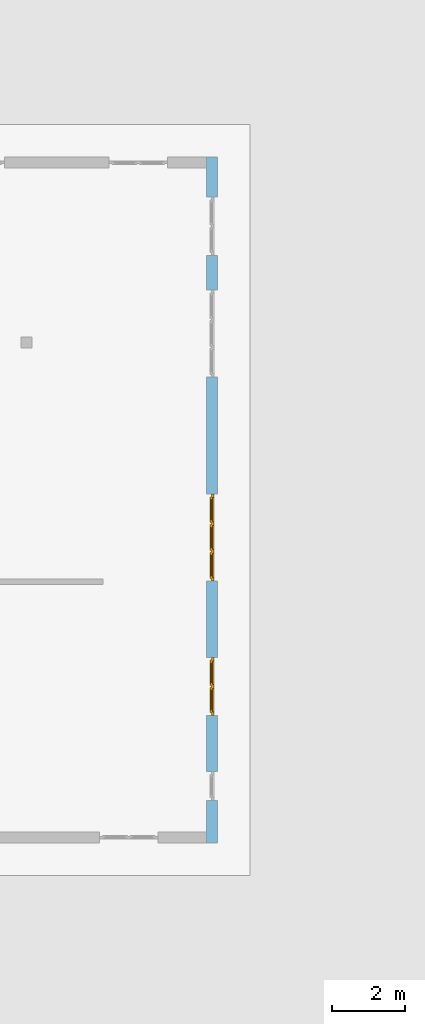
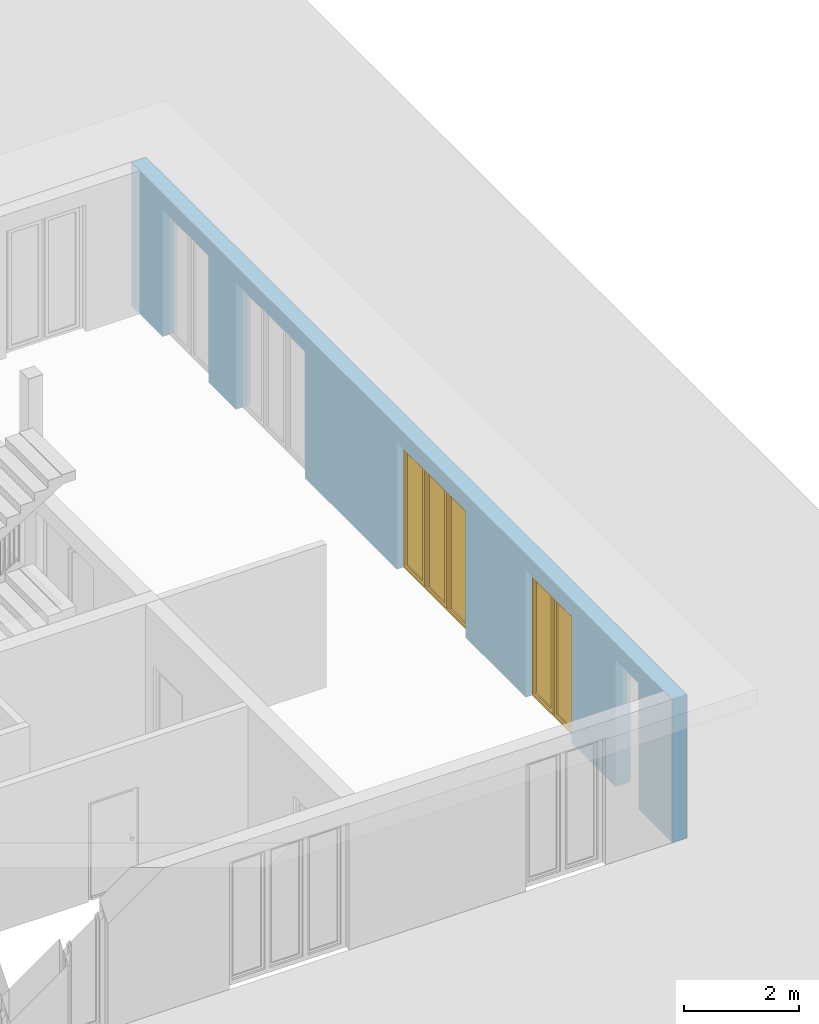
# One storey, part 13 of 23: 2 windows, 5 openings, plus 1 element that does not belong to this part.
"""IFC4 building model written with IfcOpenShell, lengths in metres."""

from ifc_helpers import new_model, entity, si_unit, converted_unit, derived_unit, direction, frame, origin_with_axes, place, context, subcontext, project, spatial, polygons, source, transform, mapped, material, type_object, element, fill, save


model = new_model("IFC4")

# Units and contexts
model_context = context("Model", 3, precision=1e-05, world=origin_with_axes(), true_north=direction((0.0, 1.0)))
body_context = subcontext(model_context, "Body", "Model", "MODEL_VIEW")
ifc_project = project(units=[si_unit("LENGTHUNIT", "METRE"), si_unit("AREAUNIT", "SQUARE_METRE"), si_unit("VOLUMEUNIT", "CUBIC_METRE"), converted_unit("PLANEANGLEUNIT", "DEGREE", entity("IfcPlaneAngleMeasure", 0.0174532925199), si_unit("PLANEANGLEUNIT", "RADIAN"), dimensions=[0, 0, 0, 0, 0, 0, 0]), converted_unit("TIMEUNIT", "Year", entity("IfcTimeMeasure", 31556926.0), si_unit("TIMEUNIT", "SECOND"), dimensions=[0, 0, 1, 0, 0, 0, 0]), si_unit("MASSUNIT", "GRAM", prefix="KILO"), si_unit("THERMODYNAMICTEMPERATUREUNIT", "DEGREE_CELSIUS"), si_unit("LUMINOUSINTENSITYUNIT", "LUMEN"), si_unit("ENERGYUNIT", "JOULE", prefix="MEGA"), derived_unit("THERMALCONDUCTANCEUNIT", [(si_unit("POWERUNIT", "WATT"), 1), (si_unit("LENGTHUNIT", "METRE"), -1), (si_unit("THERMODYNAMICTEMPERATUREUNIT", "KELVIN"), -1)]), derived_unit("SPECIFICHEATCAPACITYUNIT", [(si_unit("ENERGYUNIT", "JOULE"), 1), (si_unit("MASSUNIT", "GRAM", prefix="KILO"), -1), (si_unit("THERMODYNAMICTEMPERATUREUNIT", "KELVIN"), -1)]), derived_unit("MASSDENSITYUNIT", [(si_unit("MASSUNIT", "GRAM", prefix="KILO"), 1), (si_unit("VOLUMEUNIT", "CUBIC_METRE"), -1)])], contexts=[model_context])

# Site, building, storey
site_placement = place(None, origin_with_axes())
site = spatial("IfcSite", under=ifc_project, at=site_placement, CompositionType="ELEMENT")
building_placement = place(site_placement, origin_with_axes())
building = spatial("IfcBuilding", under=site, at=building_placement, CompositionType="ELEMENT")
storey_placement = place(building_placement, origin_with_axes())
storey = spatial("IfcBuildingStorey", under=building, at=storey_placement, Name="0. Geschoss", CompositionType="ELEMENT", Elevation=0.0)

# Wall, openings, windows
ifc_material = material()
wall_type = type_object("IfcWallType", Name="300", PredefinedType="NOTDEFINED")
wall_placement = place(storey_placement, frame((9.3378006196, -9.92881223104, 0.0), z_axis=(0.0, 0.0, 1.0), x_axis=(0.0, 1.0, 0.0)))
wall = element("IfcWall", 1, at=wall_placement, inside=storey, type_object=wall_type, material=ifc_material, Name="Wand-001", PredefinedType="NOTDEFINED", context=body_context, shape_type="Tessellation", body=[
    polygons([(1.16441876325, 0.1, 2.7), (1.96441876325, 0.1, 2.7), (1.96441876325, 0.0, 2.7), (1.16441876325, 0.0, 2.7), (1.16441876325, 0.3, 2.7), (1.96441876325, 0.3, 2.7), (1.96441876325, 0.1, 0.0), (1.96441876325, 0.0, 0.0), (18.85, 0.0, 3.05), (0.0, 0.0, 3.05), (0.0, 0.0, 0.0), (1.16441876325, 0.0, 0.0), (3.5, 0.0, 0.0), (3.5, 0.0, 2.7), (5.1, 0.0, 2.7), (5.1, 0.0, 0.0), (7.1921181063, 0.0, 0.0), (7.1921181063, 0.0, 2.7), (9.5921181063, 0.0, 2.7), (9.5921181063, 0.0, 0.0), (12.8, 0.0, 0.0), (12.8, 0.0, 2.7), (15.2, 0.0, 2.7), (15.2, 0.0, 0.0), (16.15, 0.0, 0.0), (16.15, 0.0, 2.7), (17.75, 0.0, 2.7), (17.75, 0.0, 0.0), (18.85, 0.0, 0.0), (1.16441876325, 0.1, 0.0), (1.16441876325, 0.3, 0.0), (0.0, 0.3, 0.0), (0.0, 0.3, 3.05), (18.85, 0.3, 3.05), (18.85, 0.3, 0.0), (17.75, 0.3, 0.0), (17.75, 0.3, 2.7), (16.15, 0.3, 2.7), (16.15, 0.3, 0.0), (15.2, 0.3, 0.0), (15.2, 0.3, 2.7), (12.8, 0.3, 2.7), (12.8, 0.3, 0.0), (9.5921181063, 0.3, 0.0), (9.5921181063, 0.3, 2.7), (7.1921181063, 0.3, 2.7), (7.1921181063, 0.3, 0.0), (5.1, 0.3, 0.0), (5.1, 0.3, 2.7), (3.5, 0.3, 2.7), (3.5, 0.3, 0.0), (1.96441876325, 0.3, 0.0), (3.5, 0.1, 0.0), (3.5, 0.1, 2.7), (5.1, 0.1, 2.7), (5.1, 0.1, 0.0), (7.1921181063, 0.1, 0.0), (7.1921181063, 0.1, 2.7), (9.5921181063, 0.1, 2.7), (9.5921181063, 0.1, 0.0), (12.8, 0.1, 0.0), (12.8, 0.1, 2.7), (15.2, 0.1, 2.7), (15.2, 0.1, 0.0), (16.15, 0.1, 0.0), (16.15, 0.1, 2.7), (17.75, 0.1, 2.7), (17.75, 0.1, 0.0)], [[[1, 2, 3, 4]], [[2, 1, 5, 6]], [[2, 7, 8, 3]], [[9, 10, 11, 12, 4, 3, 8, 13, 14, 15, 16, 17, 18, 19, 20, 21, 22, 23, 24, 25, 26, 27, 28, 29]], [[30, 1, 4, 12]], [[1, 30, 31, 5]], [[5, 31, 32, 33, 34, 35, 36, 37, 38, 39, 40, 41, 42, 43, 44, 45, 46, 47, 48, 49, 50, 51, 52, 6]], [[7, 2, 6, 52]], [[7, 52, 51, 53, 13, 8]], [[9, 34, 33, 10]], [[33, 32, 11, 10]], [[31, 30, 12, 11, 32]], [[14, 13, 53, 54]], [[15, 14, 54, 55]], [[16, 15, 55, 56]], [[56, 48, 47, 57, 17, 16]], [[57, 58, 18, 17]], [[58, 59, 19, 18]], [[59, 60, 20, 19]], [[60, 44, 43, 61, 21, 20]], [[22, 21, 61, 62]], [[23, 22, 62, 63]], [[24, 23, 63, 64]], [[64, 40, 39, 65, 25, 24]], [[65, 66, 26, 25]], [[66, 67, 27, 26]], [[67, 68, 28, 27]], [[36, 35, 29, 28, 68]], [[9, 29, 35, 34]], [[68, 67, 37, 36]], [[67, 66, 38, 37]], [[66, 65, 39, 38]], [[41, 40, 64, 63]], [[42, 41, 63, 62]], [[43, 42, 62, 61]], [[60, 59, 45, 44]], [[59, 58, 46, 45]], [[58, 57, 47, 46]], [[49, 48, 56, 55]], [[50, 49, 55, 54]], [[51, 50, 54, 53]]], closed=True),
])
opening_1_placement = place(wall_placement, frame((16.95, 0.0, 0.0), z_axis=(0.0, 0.0, 1.0), x_axis=(1.0, 0.0, 0.0)))
element("IfcOpeningElement", 2, at=opening_1_placement, cuts=wall, Name="Fenster-001", context=body_context, identifier="Reference", shape_type="Tessellation", body=[
    polygons([(0.8, 0.1, 0.0), (0.8, 0.1, 2.7), (0.8, -0.000999999999999, 2.7), (0.8, -0.000999999999999, 0.0), (0.8, 0.301, 0.0), (0.8, 0.301, 2.7), (-0.8, 0.1, 2.7), (-0.8, -0.000999999999999, 2.7), (-0.8, 0.301, 2.7), (-0.8, -0.000999999999999, 0.0), (-0.8, 0.1, 0.0), (-0.8, 0.301, 0.0)], [[[1, 2, 3, 4]], [[2, 1, 5, 6]], [[7, 8, 3, 2, 6, 9]], [[8, 10, 4, 3]], [[1, 4, 10, 11, 12, 5]], [[6, 5, 12, 9]], [[7, 11, 10, 8]], [[11, 7, 9, 12]]], closed=True),
])
opening_2_placement = place(wall_placement, frame((14.0, 0.0, 0.0), z_axis=(0.0, 0.0, 1.0), x_axis=(1.0, 0.0, 0.0)))
element("IfcOpeningElement", 3, at=opening_2_placement, cuts=wall, Name="Fenster-002", context=body_context, identifier="Reference", shape_type="Tessellation", body=[
    polygons([(1.2, 0.1, 0.0), (1.2, 0.1, 2.7), (1.2, -0.000999999999999, 2.7), (1.2, -0.000999999999999, 0.0), (1.2, 0.301, 0.0), (1.2, 0.301, 2.7), (-1.2, 0.1, 2.7), (-1.2, -0.000999999999999, 2.7), (-1.2, 0.301, 2.7), (-1.2, -0.000999999999999, 0.0), (-1.2, 0.1, 0.0), (-1.2, 0.301, 0.0)], [[[1, 2, 3, 4]], [[2, 1, 5, 6]], [[7, 8, 3, 2, 6, 9]], [[8, 10, 4, 3]], [[1, 4, 10, 11, 12, 5]], [[6, 5, 12, 9]], [[7, 11, 10, 8]], [[11, 7, 9, 12]]], closed=True),
])
opening_3_placement = place(wall_placement, frame((8.3921181063, 0.0, 0.0), z_axis=(0.0, 0.0, 1.0), x_axis=(1.0, 0.0, 0.0)))
opening_3 = element("IfcOpeningElement", 4, at=opening_3_placement, cuts=wall, Name="Fenster-002", context=body_context, identifier="Reference", shape_type="Tessellation", body=[
    polygons([(1.2, 0.1, 0.0), (1.2, 0.1, 2.7), (1.2, -0.000999999999999, 2.7), (1.2, -0.000999999999999, 0.0), (1.2, 0.301, 0.0), (1.2, 0.301, 2.7), (-1.2, 0.1, 2.7), (-1.2, -0.000999999999999, 2.7), (-1.2, 0.301, 2.7), (-1.2, -0.000999999999999, 0.0), (-1.2, 0.1, 0.0), (-1.2, 0.301, 0.0)], [[[1, 2, 3, 4]], [[2, 1, 5, 6]], [[7, 8, 3, 2, 6, 9]], [[8, 10, 4, 3]], [[1, 4, 10, 11, 12, 5]], [[6, 5, 12, 9]], [[7, 11, 10, 8]], [[11, 7, 9, 12]]], closed=True),
])
opening_4_placement = place(wall_placement, frame((4.3, 0.0, 0.0), z_axis=(0.0, 0.0, 1.0), x_axis=(1.0, 0.0, 0.0)))
opening_4 = element("IfcOpeningElement", 5, at=opening_4_placement, cuts=wall, Name="Fenster-001", context=body_context, identifier="Reference", shape_type="Tessellation", body=[
    polygons([(0.8, 0.1, 0.0), (0.8, 0.1, 2.7), (0.8, -0.000999999999999, 2.7), (0.8, -0.000999999999999, 0.0), (0.8, 0.301, 0.0), (0.8, 0.301, 2.7), (-0.8, 0.1, 2.7), (-0.8, -0.000999999999999, 2.7), (-0.8, 0.301, 2.7), (-0.8, -0.000999999999999, 0.0), (-0.8, 0.1, 0.0), (-0.8, 0.301, 0.0)], [[[1, 2, 3, 4]], [[2, 1, 5, 6]], [[7, 8, 3, 2, 6, 9]], [[8, 10, 4, 3]], [[1, 4, 10, 11, 12, 5]], [[6, 5, 12, 9]], [[7, 11, 10, 8]], [[11, 7, 9, 12]]], closed=True),
])
opening_5_placement = place(wall_placement, frame((1.56441876325, 0.0, 0.0), z_axis=(0.0, 0.0, 1.0), x_axis=(1.0, 0.0, 0.0)))
element("IfcOpeningElement", 6, at=opening_5_placement, cuts=wall, Name="Fenster-003", context=body_context, identifier="Reference", shape_type="Tessellation", body=[
    polygons([(0.4, 0.1, 0.0), (0.4, 0.1, 2.7), (0.4, -0.000999999999999, 2.7), (0.4, -0.000999999999999, 0.0), (0.4, 0.301, 0.0), (0.4, 0.301, 2.7), (-0.4, 0.1, 2.7), (-0.4, -0.000999999999999, 2.7), (-0.4, 0.301, 2.7), (-0.4, -0.000999999999999, 0.0), (-0.4, 0.1, 0.0), (-0.4, 0.301, 0.0)], [[[1, 2, 3, 4]], [[2, 1, 5, 6]], [[7, 8, 3, 2, 6, 9]], [[8, 10, 4, 3]], [[1, 4, 10, 11, 12, 5]], [[6, 5, 12, 9]], [[7, 11, 10, 8]], [[11, 7, 9, 12]]], closed=True),
])
window_type_1 = type_object("IfcWindowType", Name="3-1+1+1 26", PartitioningType="TRIPLE_PANEL_VERTICAL", PredefinedType="WINDOW")
shared_shape_1 = source(origin_with_axes(), body_context, "Body", "Tessellation", [
    polygons([(-1.2, -0.07, 0.0), (-1.2, 0.0, 0.0), (-1.1, 0.0, 0.1), (-1.1, -0.07, 0.1), (-1.2, -0.07, 2.7), (-1.2, 0.0, 2.7), (-1.1, 0.0, 2.6), (-1.1, -0.07, 2.6)], [[[1, 2, 3, 4]], [[5, 6, 2, 1]], [[2, 6, 7, 3]], [[4, 3, 7, 8]], [[1, 4, 8, 5]], [[8, 7, 6, 5]]], closed=True),
    polygons([(1.2, -0.07, 0.0), (1.2, 0.0, 0.0), (1.2, 0.0, 2.7), (1.2, -0.07, 2.7), (1.1, -0.07, 0.1), (1.1, 0.0, 0.1), (1.1, 0.0, 2.6), (1.1, -0.07, 2.6)], [[[1, 2, 3, 4]], [[5, 6, 2, 1]], [[2, 6, 7, 3]], [[4, 3, 7, 8]], [[1, 4, 8, 5]], [[8, 7, 6, 5]]], closed=True),
    polygons([(-1.2, -0.07, 0.0), (-1.2, 0.0, 0.0), (1.2, 0.0, 0.0), (1.2, -0.07, 0.0), (-1.1, -0.07, 0.1), (-1.1, 0.0, 0.1), (-0.433333333333, 0.0, 0.1), (-0.333333333333, 0.0, 0.1), (0.333333333333, 0.0, 0.1), (0.433333333333, 0.0, 0.1), (1.1, 0.0, 0.1), (1.1, -0.07, 0.1), (0.433333333333, -0.07, 0.1), (0.333333333333, -0.07, 0.1), (-0.333333333333, -0.07, 0.1), (-0.433333333333, -0.07, 0.1)], [[[1, 2, 3, 4]], [[5, 6, 2, 1]], [[2, 6, 7, 8, 9, 10, 11, 3]], [[4, 3, 11, 12]], [[1, 4, 12, 13, 14, 15, 16, 5]], [[16, 7, 6, 5]], [[15, 8, 7, 16]], [[14, 9, 8, 15]], [[13, 10, 9, 14]], [[12, 11, 10, 13]]], closed=True),
    polygons([(-1.2, -0.07, 2.7), (-1.2, 0.0, 2.7), (-1.1, 0.0, 2.6), (-1.1, -0.07, 2.6), (1.2, -0.07, 2.7), (1.2, 0.0, 2.7), (1.1, 0.0, 2.6), (0.433333333333, 0.0, 2.6), (0.333333333333, 0.0, 2.6), (-0.333333333333, 0.0, 2.6), (-0.433333333333, 0.0, 2.6), (-0.433333333333, -0.07, 2.6), (-0.333333333333, -0.07, 2.6), (0.333333333333, -0.07, 2.6), (0.433333333333, -0.07, 2.6), (1.1, -0.07, 2.6)], [[[1, 2, 3, 4]], [[5, 6, 2, 1]], [[2, 6, 7, 8, 9, 10, 11, 3]], [[4, 3, 11, 12]], [[1, 4, 12, 13, 14, 15, 16, 5]], [[16, 7, 6, 5]], [[15, 8, 7, 16]], [[14, 9, 8, 15]], [[13, 10, 9, 14]], [[12, 11, 10, 13]]], closed=True),
    polygons([(0.333333333333, -0.07, 0.1), (0.333333333333, 0.0, 0.1), (0.433333333333, 0.0, 0.1), (0.433333333333, -0.07, 0.1), (0.333333333333, -0.07, 2.6), (0.333333333333, 0.0, 2.6), (0.433333333333, 0.0, 2.6), (0.433333333333, -0.07, 2.6)], [[[1, 2, 3, 4]], [[5, 6, 2, 1]], [[2, 6, 7, 3]], [[4, 3, 7, 8]], [[1, 4, 8, 5]], [[8, 7, 6, 5]]], closed=True),
    polygons([(-0.433333333333, -0.07, 0.1), (-0.433333333333, 0.0, 0.1), (-0.333333333333, 0.0, 0.1), (-0.333333333333, -0.07, 0.1), (-0.433333333333, -0.07, 2.6), (-0.433333333333, 0.0, 2.6), (-0.333333333333, 0.0, 2.6), (-0.333333333333, -0.07, 2.6)], [[[1, 2, 3, 4]], [[5, 6, 2, 1]], [[2, 6, 7, 3]], [[4, 3, 7, 8]], [[1, 4, 8, 5]], [[8, 7, 6, 5]]], closed=True),
    polygons([(-1.12, 0.0, 0.08), (-1.12, 0.03, 0.08), (-1.05, 0.03, 0.15), (-1.05, 0.0, 0.15), (-1.12, 0.0, 2.62), (-1.12, 0.03, 2.62), (-1.05, 0.03, 2.55), (-1.05, 0.0, 2.55)], [[[1, 2, 3, 4]], [[5, 6, 2, 1]], [[2, 6, 7, 3]], [[4, 3, 7, 8]], [[1, 4, 8, 5]], [[8, 7, 6, 5]]], closed=True),
    polygons([(-0.413333333333, 0.0, 0.08), (-0.483333333333, 0.0, 0.15), (-0.483333333333, 0.03, 0.15), (-0.413333333333, 0.03, 0.08), (-0.413333333333, 0.0, 2.62), (-0.483333333333, 0.0, 2.55), (-0.483333333333, 0.03, 2.55), (-0.413333333333, 0.03, 2.62)], [[[1, 2, 3, 4]], [[1, 5, 6, 2]], [[2, 6, 7, 3]], [[4, 3, 7, 8]], [[5, 1, 4, 8]], [[6, 5, 8, 7]]], closed=True),
    polygons([(-1.12, 0.0, 0.08), (-1.12, 0.03, 0.08), (-0.413333333333, 0.03, 0.08), (-0.413333333333, 0.0, 0.08), (-1.05, 0.0, 0.15), (-1.05, 0.03, 0.15), (-0.483333333333, 0.03, 0.15), (-0.483333333333, 0.0, 0.15)], [[[1, 2, 3, 4]], [[5, 6, 2, 1]], [[2, 6, 7, 3]], [[4, 3, 7, 8]], [[1, 4, 8, 5]], [[8, 7, 6, 5]]], closed=True),
    polygons([(-1.12, 0.0, 2.62), (-0.413333333333, 0.0, 2.62), (-0.413333333333, 0.03, 2.62), (-1.12, 0.03, 2.62), (-1.05, 0.0, 2.55), (-0.483333333333, 0.0, 2.55), (-0.483333333333, 0.03, 2.55), (-1.05, 0.03, 2.55)], [[[1, 2, 3, 4]], [[1, 5, 6, 2]], [[2, 6, 7, 3]], [[4, 3, 7, 8]], [[5, 1, 4, 8]], [[6, 5, 8, 7]]], closed=True),
    polygons([(-1.1, -0.03, 0.1), (-1.1, 0.0, 0.1), (-1.05, 0.0, 0.15), (-1.05, -0.03, 0.15), (-1.1, -0.03, 2.6), (-1.1, 0.0, 2.6), (-1.05, 0.0, 2.55), (-1.05, -0.03, 2.55)], [[[1, 2, 3, 4]], [[5, 6, 2, 1]], [[2, 6, 7, 3]], [[4, 3, 7, 8]], [[1, 4, 8, 5]], [[8, 7, 6, 5]]], closed=True),
    polygons([(-0.433333333333, -0.03, 0.1), (-0.483333333333, -0.03, 0.15), (-0.483333333333, 0.0, 0.15), (-0.433333333333, 0.0, 0.1), (-0.433333333333, -0.03, 2.6), (-0.483333333333, -0.03, 2.55), (-0.483333333333, 0.0, 2.55), (-0.433333333333, 0.0, 2.6)], [[[1, 2, 3, 4]], [[1, 5, 6, 2]], [[2, 6, 7, 3]], [[4, 3, 7, 8]], [[5, 1, 4, 8]], [[6, 5, 8, 7]]], closed=True),
    polygons([(-1.1, -0.03, 0.1), (-1.1, 0.0, 0.1), (-0.433333333333, 0.0, 0.1), (-0.433333333333, -0.03, 0.1), (-1.05, -0.03, 0.15), (-1.05, 0.0, 0.15), (-0.483333333333, 0.0, 0.15), (-0.483333333333, -0.03, 0.15)], [[[1, 2, 3, 4]], [[5, 6, 2, 1]], [[2, 6, 7, 3]], [[4, 3, 7, 8]], [[1, 4, 8, 5]], [[8, 7, 6, 5]]], closed=True),
    polygons([(-1.1, -0.03, 2.6), (-0.433333333333, -0.03, 2.6), (-0.433333333333, 0.0, 2.6), (-1.1, 0.0, 2.6), (-1.05, -0.03, 2.55), (-0.483333333333, -0.03, 2.55), (-0.483333333333, 0.0, 2.55), (-1.05, 0.0, 2.55)], [[[1, 2, 3, 4]], [[1, 5, 6, 2]], [[2, 6, 7, 3]], [[4, 3, 7, 8]], [[5, 1, 4, 8]], [[6, 5, 8, 7]]], closed=True),
    polygons([(-1.05, -0.005, 0.15), (-1.05, 0.005, 0.15), (-0.483333333333, 0.005, 0.15), (-0.483333333333, -0.005, 0.15), (-1.05, -0.005, 2.55), (-1.05, 0.005, 2.55), (-0.483333333333, 0.005, 2.55), (-0.483333333333, -0.005, 2.55)], [[[1, 2, 3, 4]], [[5, 6, 2, 1]], [[2, 6, 7, 3]], [[4, 3, 7, 8]], [[1, 4, 8, 5]], [[8, 7, 6, 5]]], closed=True),
    polygons([(-0.353333333333, 0.0, 0.08), (-0.353333333333, 0.03, 0.08), (-0.283333333333, 0.03, 0.15), (-0.283333333333, 0.0, 0.15), (-0.353333333333, 0.0, 2.62), (-0.353333333333, 0.03, 2.62), (-0.283333333333, 0.03, 2.55), (-0.283333333333, 0.0, 2.55)], [[[1, 2, 3, 4]], [[5, 6, 2, 1]], [[2, 6, 7, 3]], [[4, 3, 7, 8]], [[1, 4, 8, 5]], [[8, 7, 6, 5]]], closed=True),
    polygons([(0.353333333333, 0.0, 0.08), (0.283333333333, 0.0, 0.15), (0.283333333333, 0.03, 0.15), (0.353333333333, 0.03, 0.08), (0.353333333333, 0.0, 2.62), (0.283333333333, 0.0, 2.55), (0.283333333333, 0.03, 2.55), (0.353333333333, 0.03, 2.62)], [[[1, 2, 3, 4]], [[1, 5, 6, 2]], [[2, 6, 7, 3]], [[4, 3, 7, 8]], [[5, 1, 4, 8]], [[6, 5, 8, 7]]], closed=True),
    polygons([(-0.353333333333, 0.0, 0.08), (-0.353333333333, 0.03, 0.08), (0.353333333333, 0.03, 0.08), (0.353333333333, 0.0, 0.08), (-0.283333333333, 0.0, 0.15), (-0.283333333333, 0.03, 0.15), (0.283333333333, 0.03, 0.15), (0.283333333333, 0.0, 0.15)], [[[1, 2, 3, 4]], [[5, 6, 2, 1]], [[2, 6, 7, 3]], [[4, 3, 7, 8]], [[1, 4, 8, 5]], [[8, 7, 6, 5]]], closed=True),
    polygons([(-0.353333333333, 0.0, 2.62), (0.353333333333, 0.0, 2.62), (0.353333333333, 0.03, 2.62), (-0.353333333333, 0.03, 2.62), (-0.283333333333, 0.0, 2.55), (0.283333333333, 0.0, 2.55), (0.283333333333, 0.03, 2.55), (-0.283333333333, 0.03, 2.55)], [[[1, 2, 3, 4]], [[1, 5, 6, 2]], [[2, 6, 7, 3]], [[4, 3, 7, 8]], [[5, 1, 4, 8]], [[6, 5, 8, 7]]], closed=True),
    polygons([(-0.333333333333, -0.03, 0.1), (-0.333333333333, 0.0, 0.1), (-0.283333333333, 0.0, 0.15), (-0.283333333333, -0.03, 0.15), (-0.333333333333, -0.03, 2.6), (-0.333333333333, 0.0, 2.6), (-0.283333333333, 0.0, 2.55), (-0.283333333333, -0.03, 2.55)], [[[1, 2, 3, 4]], [[5, 6, 2, 1]], [[2, 6, 7, 3]], [[4, 3, 7, 8]], [[1, 4, 8, 5]], [[8, 7, 6, 5]]], closed=True),
    polygons([(0.333333333333, -0.03, 0.1), (0.283333333333, -0.03, 0.15), (0.283333333333, 0.0, 0.15), (0.333333333333, 0.0, 0.1), (0.333333333333, -0.03, 2.6), (0.283333333333, -0.03, 2.55), (0.283333333333, 0.0, 2.55), (0.333333333333, 0.0, 2.6)], [[[1, 2, 3, 4]], [[1, 5, 6, 2]], [[2, 6, 7, 3]], [[4, 3, 7, 8]], [[5, 1, 4, 8]], [[6, 5, 8, 7]]], closed=True),
    polygons([(-0.333333333333, -0.03, 0.1), (-0.333333333333, 0.0, 0.1), (0.333333333333, 0.0, 0.1), (0.333333333333, -0.03, 0.1), (-0.283333333333, -0.03, 0.15), (-0.283333333333, 0.0, 0.15), (0.283333333333, 0.0, 0.15), (0.283333333333, -0.03, 0.15)], [[[1, 2, 3, 4]], [[5, 6, 2, 1]], [[2, 6, 7, 3]], [[4, 3, 7, 8]], [[1, 4, 8, 5]], [[8, 7, 6, 5]]], closed=True),
    polygons([(-0.333333333333, -0.03, 2.6), (0.333333333333, -0.03, 2.6), (0.333333333333, 0.0, 2.6), (-0.333333333333, 0.0, 2.6), (-0.283333333333, -0.03, 2.55), (0.283333333333, -0.03, 2.55), (0.283333333333, 0.0, 2.55), (-0.283333333333, 0.0, 2.55)], [[[1, 2, 3, 4]], [[1, 5, 6, 2]], [[2, 6, 7, 3]], [[4, 3, 7, 8]], [[5, 1, 4, 8]], [[6, 5, 8, 7]]], closed=True),
    polygons([(-0.283333333333, -0.005, 0.15), (-0.283333333333, 0.005, 0.15), (0.283333333333, 0.005, 0.15), (0.283333333333, -0.005, 0.15), (-0.283333333333, -0.005, 2.55), (-0.283333333333, 0.005, 2.55), (0.283333333333, 0.005, 2.55), (0.283333333333, -0.005, 2.55)], [[[1, 2, 3, 4]], [[5, 6, 2, 1]], [[2, 6, 7, 3]], [[4, 3, 7, 8]], [[1, 4, 8, 5]], [[8, 7, 6, 5]]], closed=True),
    polygons([(0.413333333333, 0.0, 0.08), (0.413333333333, 0.03, 0.08), (0.483333333333, 0.03, 0.15), (0.483333333333, 0.0, 0.15), (0.413333333333, 0.0, 2.62), (0.413333333333, 0.03, 2.62), (0.483333333333, 0.03, 2.55), (0.483333333333, 0.0, 2.55)], [[[1, 2, 3, 4]], [[5, 6, 2, 1]], [[2, 6, 7, 3]], [[4, 3, 7, 8]], [[1, 4, 8, 5]], [[8, 7, 6, 5]]], closed=True),
    polygons([(1.12, 0.0, 0.08), (1.05, 0.0, 0.15), (1.05, 0.03, 0.15), (1.12, 0.03, 0.08), (1.12, 0.0, 2.62), (1.05, 0.0, 2.55), (1.05, 0.03, 2.55), (1.12, 0.03, 2.62)], [[[1, 2, 3, 4]], [[1, 5, 6, 2]], [[2, 6, 7, 3]], [[4, 3, 7, 8]], [[5, 1, 4, 8]], [[6, 5, 8, 7]]], closed=True),
    polygons([(0.413333333333, 0.0, 0.08), (0.413333333333, 0.03, 0.08), (1.12, 0.03, 0.08), (1.12, 0.0, 0.08), (0.483333333333, 0.0, 0.15), (0.483333333333, 0.03, 0.15), (1.05, 0.03, 0.15), (1.05, 0.0, 0.15)], [[[1, 2, 3, 4]], [[5, 6, 2, 1]], [[2, 6, 7, 3]], [[4, 3, 7, 8]], [[1, 4, 8, 5]], [[8, 7, 6, 5]]], closed=True),
    polygons([(0.413333333333, 0.0, 2.62), (1.12, 0.0, 2.62), (1.12, 0.03, 2.62), (0.413333333333, 0.03, 2.62), (0.483333333333, 0.0, 2.55), (1.05, 0.0, 2.55), (1.05, 0.03, 2.55), (0.483333333333, 0.03, 2.55)], [[[1, 2, 3, 4]], [[1, 5, 6, 2]], [[2, 6, 7, 3]], [[4, 3, 7, 8]], [[5, 1, 4, 8]], [[6, 5, 8, 7]]], closed=True),
    polygons([(0.433333333333, -0.03, 0.1), (0.433333333333, 0.0, 0.1), (0.483333333333, 0.0, 0.15), (0.483333333333, -0.03, 0.15), (0.433333333333, -0.03, 2.6), (0.433333333333, 0.0, 2.6), (0.483333333333, 0.0, 2.55), (0.483333333333, -0.03, 2.55)], [[[1, 2, 3, 4]], [[5, 6, 2, 1]], [[2, 6, 7, 3]], [[4, 3, 7, 8]], [[1, 4, 8, 5]], [[8, 7, 6, 5]]], closed=True),
    polygons([(1.1, -0.03, 0.1), (1.05, -0.03, 0.15), (1.05, 0.0, 0.15), (1.1, 0.0, 0.1), (1.1, -0.03, 2.6), (1.05, -0.03, 2.55), (1.05, 0.0, 2.55), (1.1, 0.0, 2.6)], [[[1, 2, 3, 4]], [[1, 5, 6, 2]], [[2, 6, 7, 3]], [[4, 3, 7, 8]], [[5, 1, 4, 8]], [[6, 5, 8, 7]]], closed=True),
    polygons([(0.433333333333, -0.03, 0.1), (0.433333333333, 0.0, 0.1), (1.1, 0.0, 0.1), (1.1, -0.03, 0.1), (0.483333333333, -0.03, 0.15), (0.483333333333, 0.0, 0.15), (1.05, 0.0, 0.15), (1.05, -0.03, 0.15)], [[[1, 2, 3, 4]], [[5, 6, 2, 1]], [[2, 6, 7, 3]], [[4, 3, 7, 8]], [[1, 4, 8, 5]], [[8, 7, 6, 5]]], closed=True),
    polygons([(0.433333333333, -0.03, 2.6), (1.1, -0.03, 2.6), (1.1, 0.0, 2.6), (0.433333333333, 0.0, 2.6), (0.483333333333, -0.03, 2.55), (1.05, -0.03, 2.55), (1.05, 0.0, 2.55), (0.483333333333, 0.0, 2.55)], [[[1, 2, 3, 4]], [[1, 5, 6, 2]], [[2, 6, 7, 3]], [[4, 3, 7, 8]], [[5, 1, 4, 8]], [[6, 5, 8, 7]]], closed=True),
    polygons([(0.483333333333, -0.005, 0.15), (0.483333333333, 0.005, 0.15), (1.05, 0.005, 0.15), (1.05, -0.005, 0.15), (0.483333333333, -0.005, 2.55), (0.483333333333, 0.005, 2.55), (1.05, 0.005, 2.55), (1.05, -0.005, 2.55)], [[[1, 2, 3, 4]], [[5, 6, 2, 1]], [[2, 6, 7, 3]], [[4, 3, 7, 8]], [[1, 4, 8, 5]], [[8, 7, 6, 5]]], closed=True),
])
window_1_placement = place(opening_3_placement, frame((-1.2, 0.0, 0.0), z_axis=(0.0, 0.0, 1.0), x_axis=(1.0, 0.0, 0.0)))
window_1 = element("IfcWindow", 7, at=window_1_placement, inside=storey, type_object=window_type_1, Name="Fenster-002", OverallHeight=2.7, OverallWidth=2.4, PredefinedType="WINDOW", context=body_context, shape_type="MappedRepresentation", body=[
    mapped(shared_shape_1, transform((1.2, 0.17, 0.0))),
])
fill(opening_3, window_1)
window_type_2 = type_object("IfcWindowType", Name="2-1+1 26", PartitioningType="DOUBLE_PANEL_VERTICAL", PredefinedType="WINDOW")
shared_shape_2 = source(origin_with_axes(), body_context, "Body", "Tessellation", [
    polygons([(0.8, -0.07, 0.0), (0.7, -0.07, 0.1), (0.7, 0.0, 0.1), (0.8, 0.0, 0.0), (0.8, -0.07, 2.7), (0.7, -0.07, 2.6), (0.7, 0.0, 2.6), (0.8, 0.0, 2.7)], [[[1, 2, 3, 4]], [[1, 5, 6, 2]], [[2, 6, 7, 3]], [[4, 3, 7, 8]], [[5, 1, 4, 8]], [[6, 5, 8, 7]]], closed=True),
    polygons([(-0.8, -0.07, 0.0), (-0.8, -0.07, 2.7), (-0.8, 0.0, 2.7), (-0.8, 0.0, 0.0), (-0.7, -0.07, 0.1), (-0.7, -0.07, 2.6), (-0.7, 0.0, 2.6), (-0.7, 0.0, 0.1)], [[[1, 2, 3, 4]], [[1, 5, 6, 2]], [[2, 6, 7, 3]], [[4, 3, 7, 8]], [[5, 1, 4, 8]], [[6, 5, 8, 7]]], closed=True),
    polygons([(0.8, -0.07, 0.0), (-0.8, -0.07, 0.0), (-0.8, 0.0, 0.0), (0.8, 0.0, 0.0), (0.7, -0.07, 0.1), (0.05, -0.07, 0.1), (-0.05, -0.07, 0.1), (-0.7, -0.07, 0.1), (-0.7, 0.0, 0.1), (-0.05, 0.0, 0.1), (0.05, 0.0, 0.1), (0.7, 0.0, 0.1)], [[[1, 2, 3, 4]], [[1, 5, 6, 7, 8, 2]], [[2, 8, 9, 3]], [[4, 3, 9, 10, 11, 12]], [[5, 1, 4, 12]], [[6, 5, 12, 11]], [[7, 6, 11, 10]], [[8, 7, 10, 9]]], closed=True),
    polygons([(0.8, -0.07, 2.7), (0.7, -0.07, 2.6), (0.7, 0.0, 2.6), (0.8, 0.0, 2.7), (-0.8, -0.07, 2.7), (-0.7, -0.07, 2.6), (-0.05, -0.07, 2.6), (0.05, -0.07, 2.6), (0.05, 0.0, 2.6), (-0.05, 0.0, 2.6), (-0.7, 0.0, 2.6), (-0.8, 0.0, 2.7)], [[[1, 2, 3, 4]], [[1, 5, 6, 7, 8, 2]], [[2, 8, 9, 3]], [[4, 3, 9, 10, 11, 12]], [[5, 1, 4, 12]], [[6, 5, 12, 11]], [[7, 6, 11, 10]], [[8, 7, 10, 9]]], closed=True),
    polygons([(0.05, -0.07, 0.1), (-0.05, -0.07, 0.1), (-0.05, 0.0, 0.1), (0.05, 0.0, 0.1), (0.05, -0.07, 2.6), (-0.05, -0.07, 2.6), (-0.05, 0.0, 2.6), (0.05, 0.0, 2.6)], [[[1, 2, 3, 4]], [[1, 5, 6, 2]], [[2, 6, 7, 3]], [[4, 3, 7, 8]], [[5, 1, 4, 8]], [[6, 5, 8, 7]]], closed=True),
    polygons([(0.72, 0.0, 0.08), (0.65, 0.0, 0.15), (0.65, 0.03, 0.15), (0.72, 0.03, 0.08), (0.72, 0.0, 2.62), (0.65, 0.0, 2.55), (0.65, 0.03, 2.55), (0.72, 0.03, 2.62)], [[[1, 2, 3, 4]], [[1, 5, 6, 2]], [[2, 6, 7, 3]], [[4, 3, 7, 8]], [[5, 1, 4, 8]], [[6, 5, 8, 7]]], closed=True),
    polygons([(0.03, 0.0, 0.08), (0.03, 0.03, 0.08), (0.1, 0.03, 0.15), (0.1, 0.0, 0.15), (0.03, 0.0, 2.62), (0.03, 0.03, 2.62), (0.1, 0.03, 2.55), (0.1, 0.0, 2.55)], [[[1, 2, 3, 4]], [[5, 6, 2, 1]], [[2, 6, 7, 3]], [[4, 3, 7, 8]], [[1, 4, 8, 5]], [[8, 7, 6, 5]]], closed=True),
    polygons([(0.72, 0.0, 0.08), (0.03, 0.0, 0.08), (0.03, 0.03, 0.08), (0.72, 0.03, 0.08), (0.65, 0.0, 0.15), (0.1, 0.0, 0.15), (0.1, 0.03, 0.15), (0.65, 0.03, 0.15)], [[[1, 2, 3, 4]], [[1, 5, 6, 2]], [[2, 6, 7, 3]], [[4, 3, 7, 8]], [[5, 1, 4, 8]], [[6, 5, 8, 7]]], closed=True),
    polygons([(0.72, 0.0, 2.62), (0.72, 0.03, 2.62), (0.03, 0.03, 2.62), (0.03, 0.0, 2.62), (0.65, 0.0, 2.55), (0.65, 0.03, 2.55), (0.1, 0.03, 2.55), (0.1, 0.0, 2.55)], [[[1, 2, 3, 4]], [[5, 6, 2, 1]], [[2, 6, 7, 3]], [[4, 3, 7, 8]], [[1, 4, 8, 5]], [[8, 7, 6, 5]]], closed=True),
    polygons([(0.7, -0.03, 0.1), (0.65, -0.03, 0.15), (0.65, 0.0, 0.15), (0.7, 0.0, 0.1), (0.7, -0.03, 2.6), (0.65, -0.03, 2.55), (0.65, 0.0, 2.55), (0.7, 0.0, 2.6)], [[[1, 2, 3, 4]], [[1, 5, 6, 2]], [[2, 6, 7, 3]], [[4, 3, 7, 8]], [[5, 1, 4, 8]], [[6, 5, 8, 7]]], closed=True),
    polygons([(0.05, -0.03, 0.1), (0.05, 0.0, 0.1), (0.1, 0.0, 0.15), (0.1, -0.03, 0.15), (0.05, -0.03, 2.6), (0.05, 0.0, 2.6), (0.1, 0.0, 2.55), (0.1, -0.03, 2.55)], [[[1, 2, 3, 4]], [[5, 6, 2, 1]], [[2, 6, 7, 3]], [[4, 3, 7, 8]], [[1, 4, 8, 5]], [[8, 7, 6, 5]]], closed=True),
    polygons([(0.7, -0.03, 0.1), (0.05, -0.03, 0.1), (0.05, 0.0, 0.1), (0.7, 0.0, 0.1), (0.65, -0.03, 0.15), (0.1, -0.03, 0.15), (0.1, 0.0, 0.15), (0.65, 0.0, 0.15)], [[[1, 2, 3, 4]], [[1, 5, 6, 2]], [[2, 6, 7, 3]], [[4, 3, 7, 8]], [[5, 1, 4, 8]], [[6, 5, 8, 7]]], closed=True),
    polygons([(0.7, -0.03, 2.6), (0.7, 0.0, 2.6), (0.05, 0.0, 2.6), (0.05, -0.03, 2.6), (0.65, -0.03, 2.55), (0.65, 0.0, 2.55), (0.1, 0.0, 2.55), (0.1, -0.03, 2.55)], [[[1, 2, 3, 4]], [[5, 6, 2, 1]], [[2, 6, 7, 3]], [[4, 3, 7, 8]], [[1, 4, 8, 5]], [[8, 7, 6, 5]]], closed=True),
    polygons([(0.65, -0.005, 0.15), (0.1, -0.005, 0.15), (0.1, 0.005, 0.15), (0.65, 0.005, 0.15), (0.65, -0.005, 2.55), (0.1, -0.005, 2.55), (0.1, 0.005, 2.55), (0.65, 0.005, 2.55)], [[[1, 2, 3, 4]], [[1, 5, 6, 2]], [[2, 6, 7, 3]], [[4, 3, 7, 8]], [[5, 1, 4, 8]], [[6, 5, 8, 7]]], closed=True),
    polygons([(-0.03, 0.0, 0.08), (-0.1, 0.0, 0.15), (-0.1, 0.03, 0.15), (-0.03, 0.03, 0.08), (-0.03, 0.0, 2.62), (-0.1, 0.0, 2.55), (-0.1, 0.03, 2.55), (-0.03, 0.03, 2.62)], [[[1, 2, 3, 4]], [[1, 5, 6, 2]], [[2, 6, 7, 3]], [[4, 3, 7, 8]], [[5, 1, 4, 8]], [[6, 5, 8, 7]]], closed=True),
    polygons([(-0.72, 0.0, 0.08), (-0.72, 0.03, 0.08), (-0.65, 0.03, 0.15), (-0.65, 0.0, 0.15), (-0.72, 0.0, 2.62), (-0.72, 0.03, 2.62), (-0.65, 0.03, 2.55), (-0.65, 0.0, 2.55)], [[[1, 2, 3, 4]], [[5, 6, 2, 1]], [[2, 6, 7, 3]], [[4, 3, 7, 8]], [[1, 4, 8, 5]], [[8, 7, 6, 5]]], closed=True),
    polygons([(-0.03, 0.0, 0.08), (-0.72, 0.0, 0.08), (-0.72, 0.03, 0.08), (-0.03, 0.03, 0.08), (-0.1, 0.0, 0.15), (-0.65, 0.0, 0.15), (-0.65, 0.03, 0.15), (-0.1, 0.03, 0.15)], [[[1, 2, 3, 4]], [[1, 5, 6, 2]], [[2, 6, 7, 3]], [[4, 3, 7, 8]], [[5, 1, 4, 8]], [[6, 5, 8, 7]]], closed=True),
    polygons([(-0.03, 0.0, 2.62), (-0.03, 0.03, 2.62), (-0.72, 0.03, 2.62), (-0.72, 0.0, 2.62), (-0.1, 0.0, 2.55), (-0.1, 0.03, 2.55), (-0.65, 0.03, 2.55), (-0.65, 0.0, 2.55)], [[[1, 2, 3, 4]], [[5, 6, 2, 1]], [[2, 6, 7, 3]], [[4, 3, 7, 8]], [[1, 4, 8, 5]], [[8, 7, 6, 5]]], closed=True),
    polygons([(-0.05, -0.03, 0.1), (-0.1, -0.03, 0.15), (-0.1, 0.0, 0.15), (-0.05, 0.0, 0.1), (-0.05, -0.03, 2.6), (-0.1, -0.03, 2.55), (-0.1, 0.0, 2.55), (-0.05, 0.0, 2.6)], [[[1, 2, 3, 4]], [[1, 5, 6, 2]], [[2, 6, 7, 3]], [[4, 3, 7, 8]], [[5, 1, 4, 8]], [[6, 5, 8, 7]]], closed=True),
    polygons([(-0.7, -0.03, 0.1), (-0.7, 0.0, 0.1), (-0.65, 0.0, 0.15), (-0.65, -0.03, 0.15), (-0.7, -0.03, 2.6), (-0.7, 0.0, 2.6), (-0.65, 0.0, 2.55), (-0.65, -0.03, 2.55)], [[[1, 2, 3, 4]], [[5, 6, 2, 1]], [[2, 6, 7, 3]], [[4, 3, 7, 8]], [[1, 4, 8, 5]], [[8, 7, 6, 5]]], closed=True),
    polygons([(-0.05, -0.03, 0.1), (-0.7, -0.03, 0.1), (-0.7, 0.0, 0.1), (-0.05, 0.0, 0.1), (-0.1, -0.03, 0.15), (-0.65, -0.03, 0.15), (-0.65, 0.0, 0.15), (-0.1, 0.0, 0.15)], [[[1, 2, 3, 4]], [[1, 5, 6, 2]], [[2, 6, 7, 3]], [[4, 3, 7, 8]], [[5, 1, 4, 8]], [[6, 5, 8, 7]]], closed=True),
    polygons([(-0.05, -0.03, 2.6), (-0.05, 0.0, 2.6), (-0.7, 0.0, 2.6), (-0.7, -0.03, 2.6), (-0.1, -0.03, 2.55), (-0.1, 0.0, 2.55), (-0.65, 0.0, 2.55), (-0.65, -0.03, 2.55)], [[[1, 2, 3, 4]], [[5, 6, 2, 1]], [[2, 6, 7, 3]], [[4, 3, 7, 8]], [[1, 4, 8, 5]], [[8, 7, 6, 5]]], closed=True),
    polygons([(-0.1, -0.005, 0.15), (-0.65, -0.005, 0.15), (-0.65, 0.005, 0.15), (-0.1, 0.005, 0.15), (-0.1, -0.005, 2.55), (-0.65, -0.005, 2.55), (-0.65, 0.005, 2.55), (-0.1, 0.005, 2.55)], [[[1, 2, 3, 4]], [[1, 5, 6, 2]], [[2, 6, 7, 3]], [[4, 3, 7, 8]], [[5, 1, 4, 8]], [[6, 5, 8, 7]]], closed=True),
])
window_2_placement = place(opening_4_placement, frame((-0.8, 0.0, 0.0), z_axis=(0.0, 0.0, 1.0), x_axis=(1.0, 0.0, 0.0)))
window_2 = element("IfcWindow", 8, at=window_2_placement, inside=storey, type_object=window_type_2, Name="Fenster-001", OverallHeight=2.7, OverallWidth=1.6, PredefinedType="WINDOW", context=body_context, shape_type="MappedRepresentation", body=[
    mapped(shared_shape_2, transform((0.8, 0.17, 0.0))),
])
fill(opening_4, window_2)

save(model, "model.ifc")
